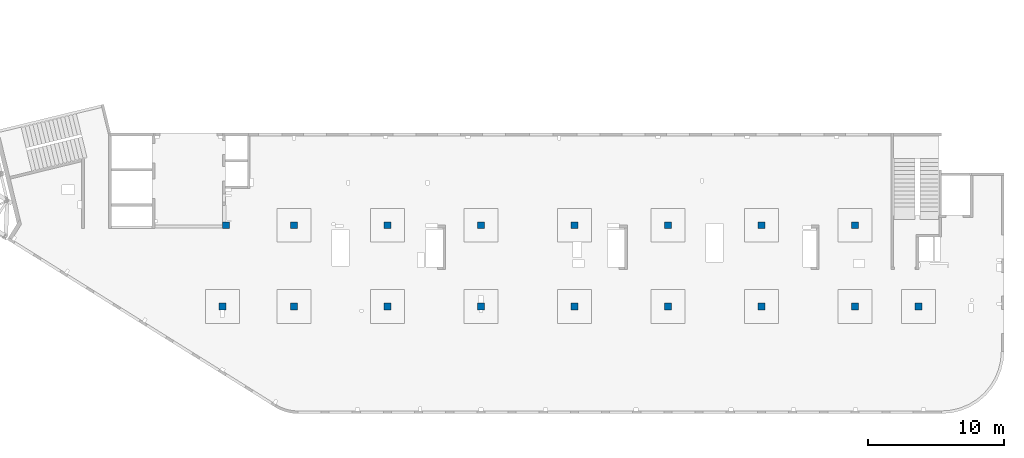
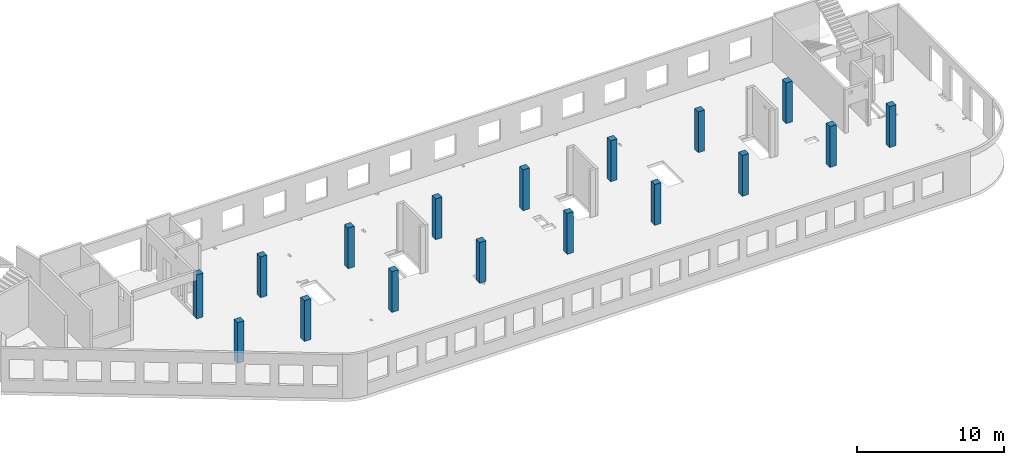
# One storey, part 4 of 92: 17 columns.
"""IFC4 building model written with IfcOpenShell, lengths in millimetres."""

from ifc_helpers import new_model, entity, si_unit, converted_unit, derived_unit, direction, frame, origin, place, context, subcontext, project, spatial, indexed_curve, outline, extrude, source, transform, mapped, material, type_object, type_shapes, element, save


model = new_model("IFC4")

# Units and contexts
model_context = context("Model", 3, precision=0.01, world=origin(), true_north=direction((6.12303176911189e-17, 1.0)))
plan_context = context("Plan", 3, precision=0.01, world=origin(), true_north=direction((6.12303176911189e-17, 1.0)))
body_context = subcontext(model_context, "Body", "Model", "MODEL_VIEW")
ifc_project = project(units=[si_unit("LENGTHUNIT", "METRE", prefix="MILLI"), si_unit("AREAUNIT", "SQUARE_METRE"), si_unit("VOLUMEUNIT", "CUBIC_METRE"), converted_unit("PLANEANGLEUNIT", "DEGREE", entity("IfcRatioMeasure", 0.0174532925199433), si_unit("PLANEANGLEUNIT", "RADIAN"), dimensions=[0, 0, 0, 0, 0, 0, 0]), si_unit("MASSUNIT", "GRAM", prefix="KILO"), derived_unit("MASSDENSITYUNIT", [(si_unit("MASSUNIT", "GRAM", prefix="KILO"), 1), (si_unit("LENGTHUNIT", "METRE"), -3)]), derived_unit("MOMENTOFINERTIAUNIT", [(si_unit("LENGTHUNIT", "METRE"), 4)]), si_unit("TIMEUNIT", "SECOND"), si_unit("FREQUENCYUNIT", "HERTZ"), si_unit("THERMODYNAMICTEMPERATUREUNIT", "DEGREE_CELSIUS"), derived_unit("THERMALTRANSMITTANCEUNIT", [(si_unit("MASSUNIT", "GRAM", prefix="KILO"), 1), (si_unit("THERMODYNAMICTEMPERATUREUNIT", "KELVIN"), -1), (si_unit("TIMEUNIT", "SECOND"), -3)]), derived_unit("VOLUMETRICFLOWRATEUNIT", [(si_unit("LENGTHUNIT", "METRE"), 3), (si_unit("TIMEUNIT", "SECOND"), -1)]), derived_unit("MASSFLOWRATEUNIT", [(si_unit("MASSUNIT", "GRAM", prefix="KILO"), 1), (si_unit("TIMEUNIT", "SECOND"), -1)]), derived_unit("ROTATIONALFREQUENCYUNIT", [(si_unit("TIMEUNIT", "SECOND"), -1)]), si_unit("ELECTRICCURRENTUNIT", "AMPERE"), si_unit("ELECTRICVOLTAGEUNIT", "VOLT"), si_unit("POWERUNIT", "WATT"), si_unit("FORCEUNIT", "NEWTON", prefix="KILO"), si_unit("ILLUMINANCEUNIT", "LUX"), si_unit("LUMINOUSFLUXUNIT", "LUMEN"), si_unit("LUMINOUSINTENSITYUNIT", "CANDELA"), derived_unit("USERDEFINED", [(si_unit("MASSUNIT", "GRAM", prefix="KILO"), -1), (si_unit("LENGTHUNIT", "METRE"), -2), (si_unit("TIMEUNIT", "SECOND"), 3), (si_unit("LUMINOUSFLUXUNIT", "LUMEN"), 1)]), derived_unit("LINEARVELOCITYUNIT", [(si_unit("LENGTHUNIT", "METRE"), 1), (si_unit("TIMEUNIT", "SECOND"), -1)]), si_unit("PRESSUREUNIT", "PASCAL"), derived_unit("USERDEFINED", [(si_unit("LENGTHUNIT", "METRE"), -2), (si_unit("MASSUNIT", "GRAM", prefix="KILO"), 1), (si_unit("TIMEUNIT", "SECOND"), -2)]), derived_unit("LINEARFORCEUNIT", [(si_unit("MASSUNIT", "GRAM", prefix="KILO"), 1), (si_unit("LENGTHUNIT", "METRE"), 1), (si_unit("TIMEUNIT", "SECOND"), -2), (si_unit("LENGTHUNIT", "METRE"), -1)]), derived_unit("PLANARFORCEUNIT", [(si_unit("MASSUNIT", "GRAM", prefix="KILO"), 1), (si_unit("LENGTHUNIT", "METRE"), 1), (si_unit("TIMEUNIT", "SECOND"), -2), (si_unit("LENGTHUNIT", "METRE"), -2)])], contexts=[model_context, plan_context])

# Site, building, storey
site_placement = place(None, origin())
site = spatial("IfcSite", under=ifc_project, at=site_placement, CompositionType="ELEMENT")
building_placement = place(site_placement, origin())
building = spatial("IfcBuilding", under=site, at=building_placement, CompositionType="ELEMENT")
storey_placement = place(building_placement, frame((0.0, 0.0, 15900.0)))
storey = spatial("IfcBuildingStorey", under=building, at=storey_placement, Name="05", CompositionType="ELEMENT", Elevation=15900.0)

# Columns
ifc_material = material()
column_type_1 = type_object("IfcColumnType", PredefinedType="COLUMN", material=ifc_material)
shared_shape_1 = source(origin(), body_context, "Body", "SweptSolid", [
    extrude(outline(indexed_curve([(-249.999999999999, -249.999999999999), (250.000000000001, -249.999999999999), (249.999999999999, 249.999999999999), (-250.000000000001, 249.999999999999), (-249.999999999999, -249.999999999999)], self_intersect=False)), frame((15900.0, 7700.0, 15750.0), z_axis=(0.0, 0.0, 1.0), x_axis=(0.0, -1.0, 0.0)), (0.0, 0.0, 1.0), 3400.0),
])
type_shapes(column_type_1, [shared_shape_1])
placement = place(storey_placement, frame((0.0, 0.0, -15900.0)))
element("IfcColumn", 1, at=placement, inside=storey, type_object=column_type_1, PredefinedType="COLUMN", context=body_context, shape_type="MappedRepresentation", body=[
    mapped(shared_shape_1, transform((0.0, 0.0, 0.0), scale=1.0)),
])
column_type_2 = type_object("IfcColumnType", PredefinedType="COLUMN", material=ifc_material)
shared_shape_2 = source(origin(), body_context, "Body", "SweptSolid", [
    extrude(outline(indexed_curve([(-249.999999999999, -249.999999999999), (250.000000000001, -249.999999999999), (249.999999999999, 249.999999999999), (-250.000000000001, 249.999999999999), (-249.999999999999, -249.999999999999)], self_intersect=False)), frame((21170.0, 7700.0, 15750.0), z_axis=(0.0, 0.0, 1.0), x_axis=(0.0, -1.0, 0.0)), (0.0, 0.0, 1.0), 3400.0),
])
type_shapes(column_type_2, [shared_shape_2])
element("IfcColumn", 2, at=placement, inside=storey, type_object=column_type_2, PredefinedType="COLUMN", context=body_context, shape_type="MappedRepresentation", body=[
    mapped(shared_shape_2, transform((0.0, 0.0, 0.0), scale=1.0)),
])
column_type_3 = type_object("IfcColumnType", PredefinedType="COLUMN", material=ifc_material)
shared_shape_3 = source(origin(), body_context, "Body", "SweptSolid", [
    extrude(outline(indexed_curve([(-249.999999999999, -249.999999999999), (250.000000000001, -249.999999999999), (250.000000000001, 249.999999999999), (-249.999999999999, 249.999999999999), (-249.999999999999, -249.999999999999)], self_intersect=False)), frame((28070.0, 7700.0, 15750.0), z_axis=(0.0, 0.0, 1.0), x_axis=(0.0, -1.0, 0.0)), (0.0, 0.0, 1.0), 3400.0),
])
type_shapes(column_type_3, [shared_shape_3])
element("IfcColumn", 3, at=placement, inside=storey, type_object=column_type_3, PredefinedType="COLUMN", context=body_context, shape_type="MappedRepresentation", body=[
    mapped(shared_shape_3, transform((0.0, 0.0, 0.0), scale=1.0)),
])
column_type_4 = type_object("IfcColumnType", PredefinedType="COLUMN", material=ifc_material)
shared_shape_4 = source(origin(), body_context, "Body", "SweptSolid", [
    extrude(outline(indexed_curve([(-249.999999999999, -249.999999999999), (250.000000000001, -249.999999999999), (249.999999999999, 249.999999999999), (-250.000000000001, 249.999999999999), (-249.999999999999, -249.999999999999)], self_intersect=False)), frame((34970.0, 7700.0, 15750.0), z_axis=(0.0, 0.0, 1.0), x_axis=(0.0, -1.0, 0.0)), (0.0, 0.0, 1.0), 3400.0),
])
type_shapes(column_type_4, [shared_shape_4])
element("IfcColumn", 4, at=placement, inside=storey, type_object=column_type_4, PredefinedType="COLUMN", context=body_context, shape_type="MappedRepresentation", body=[
    mapped(shared_shape_4, transform((0.0, 0.0, 0.0), scale=1.0)),
])
column_type_5 = type_object("IfcColumnType", PredefinedType="COLUMN", material=ifc_material)
shared_shape_5 = source(origin(), body_context, "Body", "SweptSolid", [
    extrude(outline(indexed_curve([(-249.999999999999, -250.000000000004), (250.000000000001, -250.000000000004), (250.000000000001, 249.999999999995), (-249.999999999999, 250.000000000004), (-249.999999999999, -250.000000000004)], self_intersect=False)), frame((41870.0, 7700.0, 15750.0), z_axis=(0.0, 0.0, 1.0), x_axis=(0.0, -1.0, 0.0)), (0.0, 0.0, 1.0), 3400.0),
])
type_shapes(column_type_5, [shared_shape_5])
element("IfcColumn", 5, at=placement, inside=storey, type_object=column_type_5, PredefinedType="COLUMN", context=body_context, shape_type="MappedRepresentation", body=[
    mapped(shared_shape_5, transform((0.0, 0.0, 0.0), scale=1.0)),
])
column_type_6 = type_object("IfcColumnType", PredefinedType="COLUMN", material=ifc_material)
shared_shape_6 = source(origin(), body_context, "Body", "SweptSolid", [
    extrude(outline(indexed_curve([(-249.999999999999, -250.000000000004), (250.000000000001, -250.000000000004), (249.999999999999, 249.999999999995), (-250.000000000001, 250.000000000004), (-249.999999999999, -250.000000000004)], self_intersect=False)), frame((48770.0, 7700.0, 15750.0), z_axis=(0.0, 0.0, 1.0), x_axis=(0.0, -1.0, 0.0)), (0.0, 0.0, 1.0), 3400.0),
])
type_shapes(column_type_6, [shared_shape_6])
element("IfcColumn", 6, at=placement, inside=storey, type_object=column_type_6, PredefinedType="COLUMN", context=body_context, shape_type="MappedRepresentation", body=[
    mapped(shared_shape_6, transform((0.0, 0.0, 0.0), scale=1.0)),
])
column_type_7 = type_object("IfcColumnType", PredefinedType="COLUMN", material=ifc_material)
shared_shape_7 = source(origin(), body_context, "Body", "SweptSolid", [
    extrude(outline(indexed_curve([(-249.999999999999, -250.000000000004), (250.000000000001, -250.000000000004), (250.000000000001, 249.999999999995), (-249.999999999999, 250.000000000004), (-249.999999999999, -250.000000000004)], self_intersect=False)), frame((55670.0, 7700.0, 15750.0), z_axis=(0.0, 0.0, 1.0), x_axis=(0.0, -1.0, 0.0)), (0.0, 0.0, 1.0), 3400.0),
])
type_shapes(column_type_7, [shared_shape_7])
element("IfcColumn", 7, at=placement, inside=storey, type_object=column_type_7, PredefinedType="COLUMN", context=body_context, shape_type="MappedRepresentation", body=[
    mapped(shared_shape_7, transform((0.0, 0.0, 0.0), scale=1.0)),
])
column_type_8 = type_object("IfcColumnType", PredefinedType="COLUMN", material=ifc_material)
shared_shape_8 = source(origin(), body_context, "Body", "SweptSolid", [
    extrude(outline(indexed_curve([(-249.999999999999, -250.000000000004), (250.000000000001, -250.000000000004), (249.999999999999, 249.999999999995), (-250.000000000001, 250.000000000004), (-249.999999999999, -250.000000000004)], self_intersect=False)), frame((62570.0, 7700.0, 15750.0), z_axis=(0.0, 0.0, 1.0), x_axis=(0.0, -1.0, 0.0)), (0.0, 0.0, 1.0), 3400.0),
])
type_shapes(column_type_8, [shared_shape_8])
element("IfcColumn", 8, at=placement, inside=storey, type_object=column_type_8, PredefinedType="COLUMN", context=body_context, shape_type="MappedRepresentation", body=[
    mapped(shared_shape_8, transform((0.0, 0.0, 0.0), scale=1.0)),
])
column_type_9 = type_object("IfcColumnType", PredefinedType="COLUMN", material=ifc_material)
shared_shape_9 = source(origin(), body_context, "Body", "SweptSolid", [
    extrude(outline(indexed_curve([(-249.999999999999, -250.000000000004), (250.000000000001, -250.000000000004), (249.999999999999, 249.999999999995), (-250.000000000001, 250.000000000004), (-249.999999999999, -250.000000000004)], self_intersect=False)), frame((67270.0, 7700.0, 15750.0), z_axis=(0.0, 0.0, 1.0), x_axis=(0.0, -1.0, 0.0)), (0.0, 0.0, 1.0), 3400.0),
])
type_shapes(column_type_9, [shared_shape_9])
element("IfcColumn", 9, at=placement, inside=storey, type_object=column_type_9, PredefinedType="COLUMN", context=body_context, shape_type="MappedRepresentation", body=[
    mapped(shared_shape_9, transform((0.0, 0.0, 0.0), scale=1.0)),
])
column_type_10 = type_object("IfcColumnType", PredefinedType="COLUMN", material=ifc_material)
shared_shape_10 = source(origin(), body_context, "Body", "SweptSolid", [
    extrude(outline(indexed_curve([(-249.999999999999, -250.000000000004), (249.999999999999, -250.000000000004), (249.999999999999, 249.999999999995), (-249.999999999999, 250.000000000004), (-249.999999999999, -250.000000000004)], self_intersect=False)), frame((62570.0, 13700.0, 15750.0), z_axis=(0.0, 0.0, 1.0), x_axis=(0.0, -1.0, 0.0)), (0.0, 0.0, 1.0), 3400.0),
])
type_shapes(column_type_10, [shared_shape_10])
element("IfcColumn", 10, at=placement, inside=storey, type_object=column_type_10, PredefinedType="COLUMN", context=body_context, shape_type="MappedRepresentation", body=[
    mapped(shared_shape_10, transform((0.0, 0.0, 0.0), scale=1.0)),
])
column_type_11 = type_object("IfcColumnType", PredefinedType="COLUMN", material=ifc_material)
shared_shape_11 = source(origin(), body_context, "Body", "SweptSolid", [
    extrude(outline(indexed_curve([(-249.999999999999, -250.000000000004), (249.999999999999, -250.000000000004), (249.999999999999, 249.999999999995), (-249.999999999999, 250.000000000004), (-249.999999999999, -250.000000000004)], self_intersect=False)), frame((55670.0, 13700.0, 15750.0), z_axis=(0.0, 0.0, 1.0), x_axis=(0.0, -1.0, 0.0)), (0.0, 0.0, 1.0), 3400.0),
])
type_shapes(column_type_11, [shared_shape_11])
element("IfcColumn", 11, at=placement, inside=storey, type_object=column_type_11, PredefinedType="COLUMN", context=body_context, shape_type="MappedRepresentation", body=[
    mapped(shared_shape_11, transform((0.0, 0.0, 0.0), scale=1.0)),
])
column_type_12 = type_object("IfcColumnType", PredefinedType="COLUMN", material=ifc_material)
shared_shape_12 = source(origin(), body_context, "Body", "SweptSolid", [
    extrude(outline(indexed_curve([(-249.999999999999, -250.000000000004), (249.999999999999, -250.000000000004), (249.999999999999, 249.999999999995), (-249.999999999999, 250.000000000004), (-249.999999999999, -250.000000000004)], self_intersect=False)), frame((48770.0, 13700.0, 15750.0), z_axis=(0.0, 0.0, 1.0), x_axis=(0.0, -1.0, 0.0)), (0.0, 0.0, 1.0), 3400.0),
])
type_shapes(column_type_12, [shared_shape_12])
element("IfcColumn", 12, at=placement, inside=storey, type_object=column_type_12, PredefinedType="COLUMN", context=body_context, shape_type="MappedRepresentation", body=[
    mapped(shared_shape_12, transform((0.0, 0.0, 0.0), scale=1.0)),
])
column_type_13 = type_object("IfcColumnType", PredefinedType="COLUMN", material=ifc_material)
shared_shape_13 = source(origin(), body_context, "Body", "SweptSolid", [
    extrude(outline(indexed_curve([(-249.999999999999, -250.000000000004), (249.999999999999, -250.000000000004), (249.999999999999, 249.999999999995), (-249.999999999999, 250.000000000004), (-249.999999999999, -250.000000000004)], self_intersect=False)), frame((41870.0, 13700.0, 15750.0), z_axis=(0.0, 0.0, 1.0), x_axis=(0.0, -1.0, 0.0)), (0.0, 0.0, 1.0), 3400.0),
])
type_shapes(column_type_13, [shared_shape_13])
element("IfcColumn", 13, at=placement, inside=storey, type_object=column_type_13, PredefinedType="COLUMN", context=body_context, shape_type="MappedRepresentation", body=[
    mapped(shared_shape_13, transform((0.0, 0.0, 0.0), scale=1.0)),
])
column_type_14 = type_object("IfcColumnType", PredefinedType="COLUMN", material=ifc_material)
shared_shape_14 = source(origin(), body_context, "Body", "SweptSolid", [
    extrude(outline(indexed_curve([(-249.999999999999, -249.999999999999), (249.999999999999, -249.999999999999), (249.999999999999, 249.999999999999), (-249.999999999999, 249.999999999999), (-249.999999999999, -249.999999999999)], self_intersect=False)), frame((34970.0, 13700.0, 15750.0), z_axis=(0.0, 0.0, 1.0), x_axis=(0.0, -1.0, 0.0)), (0.0, 0.0, 1.0), 3400.0),
])
type_shapes(column_type_14, [shared_shape_14])
element("IfcColumn", 14, at=placement, inside=storey, type_object=column_type_14, PredefinedType="COLUMN", context=body_context, shape_type="MappedRepresentation", body=[
    mapped(shared_shape_14, transform((0.0, 0.0, 0.0), scale=1.0)),
])
column_type_15 = type_object("IfcColumnType", PredefinedType="COLUMN", material=ifc_material)
shared_shape_15 = source(origin(), body_context, "Body", "SweptSolid", [
    extrude(outline(indexed_curve([(-249.999999999999, -249.999999999999), (249.999999999999, -249.999999999999), (249.999999999999, 249.999999999999), (-249.999999999999, 249.999999999999), (-249.999999999999, -249.999999999999)], self_intersect=False)), frame((28070.0, 13700.0, 15750.0), z_axis=(0.0, 0.0, 1.0), x_axis=(0.0, -1.0, 0.0)), (0.0, 0.0, 1.0), 3400.0),
])
type_shapes(column_type_15, [shared_shape_15])
element("IfcColumn", 15, at=placement, inside=storey, type_object=column_type_15, PredefinedType="COLUMN", context=body_context, shape_type="MappedRepresentation", body=[
    mapped(shared_shape_15, transform((0.0, 0.0, 0.0), scale=1.0)),
])
column_type_16 = type_object("IfcColumnType", PredefinedType="COLUMN", material=ifc_material)
shared_shape_16 = source(origin(), body_context, "Body", "SweptSolid", [
    extrude(outline(indexed_curve([(-249.999999999999, -249.999999999999), (249.999999999999, -249.999999999999), (249.999999999999, 249.999999999999), (-249.999999999999, 249.999999999999), (-249.999999999999, -249.999999999999)], self_intersect=False)), frame((21170.0, 13700.0, 15750.0), z_axis=(0.0, 0.0, 1.0), x_axis=(0.0, -1.0, 0.0)), (0.0, 0.0, 1.0), 3400.0),
])
type_shapes(column_type_16, [shared_shape_16])
element("IfcColumn", 16, at=placement, inside=storey, type_object=column_type_16, PredefinedType="COLUMN", context=body_context, shape_type="MappedRepresentation", body=[
    mapped(shared_shape_16, transform((0.0, 0.0, 0.0), scale=1.0)),
])
column_type_17 = type_object("IfcColumnType", PredefinedType="COLUMN", material=ifc_material)
shared_shape_17 = source(origin(), body_context, "Body", "SweptSolid", [
    extrude(outline(indexed_curve([(-249.999999999999, -249.999999999999), (249.999999999999, -249.999999999999), (249.999999999999, 249.999999999999), (-249.999999999999, 249.999999999999), (-249.999999999999, -249.999999999999)], self_intersect=False)), frame((16150.0, 13700.0, 15750.0), z_axis=(0.0, 0.0, 1.0), x_axis=(0.0, -1.0, 0.0)), (0.0, 0.0, 1.0), 3650.0),
])
type_shapes(column_type_17, [shared_shape_17])
element("IfcColumn", 17, at=placement, inside=storey, type_object=column_type_17, PredefinedType="COLUMN", context=body_context, shape_type="MappedRepresentation", body=[
    mapped(shared_shape_17, transform((0.0, 0.0, 0.0), scale=1.0)),
])

save(model, "model.ifc")
